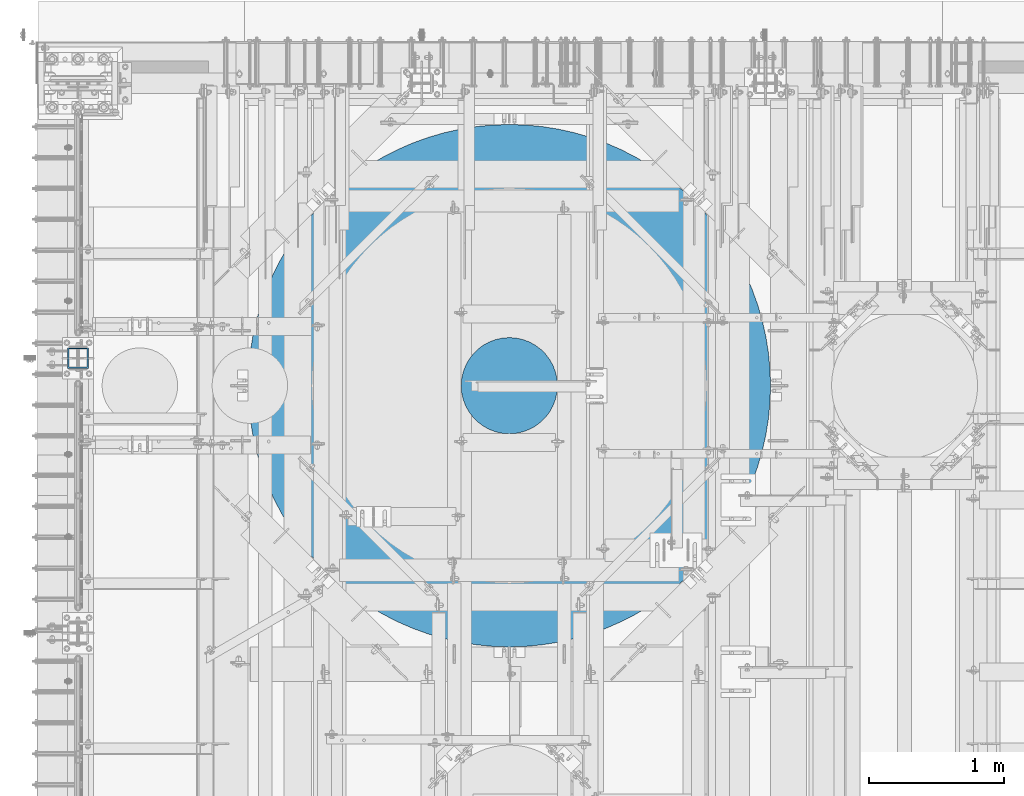
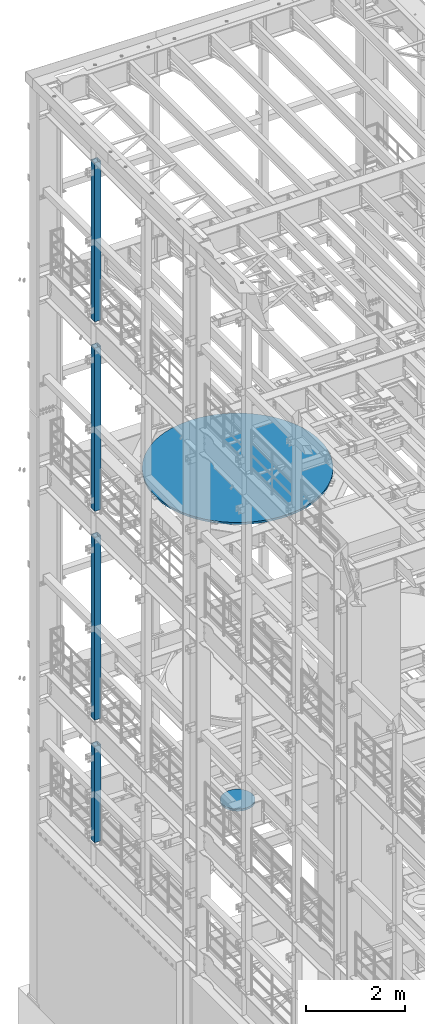
# One storey, part 743 of 1876: 6 columns, 6 elements without a shape of their own.
"""IFC2X3 building model written with IfcOpenShell, lengths in millimetres."""

from ifc_helpers import new_model, si_unit, frame, origin_with_axes, place, context, subcontext, project, spatial, faceted_brep, material, type_object, element, aggregate, save


model = new_model("IFC2X3")

# Units and contexts
model_context = context("Model", 3, precision=1e-05, world=origin_with_axes())
body_context = subcontext(model_context, "Body", "Model", "MODEL_VIEW")
ifc_project = project(units=[si_unit("LENGTHUNIT", "METRE", prefix="MILLI"), si_unit("AREAUNIT", "SQUARE_METRE"), si_unit("VOLUMEUNIT", "CUBIC_METRE"), si_unit("MASSUNIT", "GRAM", prefix="KILO"), si_unit("TIMEUNIT", "SECOND"), si_unit("PLANEANGLEUNIT", "RADIAN"), si_unit("SOLIDANGLEUNIT", "STERADIAN"), si_unit("THERMODYNAMICTEMPERATUREUNIT", "DEGREE_CELSIUS"), si_unit("LUMINOUSINTENSITYUNIT", "LUMEN")], contexts=[model_context])

# Site, building, storey
site_placement = place(None, origin_with_axes())
site = spatial("IfcSite", under=ifc_project, at=site_placement, CompositionType="ELEMENT")
building_placement = place(site_placement, origin_with_axes())
building = spatial("IfcBuilding", under=site, at=building_placement, Name="Undefined", CompositionType="ELEMENT")
storey_placement = place(building_placement, origin_with_axes())
storey = spatial("IfcBuildingStorey", under=building, at=storey_placement, Name="Undefined", CompositionType="ELEMENT", Elevation=0.0)

# Assembly, column
assembly_1_placement = place(storey_placement, origin_with_axes())
assembly_1 = element("IfcElementAssembly", 1, at=assembly_1_placement, inside=storey, Name="BEAM", AssemblyPlace="NOTDEFINED", PredefinedType="RIGID_FRAME")
ifc_material_1 = material()
column_type_1 = type_object("IfcColumnType", Name="HSS6X6X3/8", PredefinedType="NOTDEFINED")
column_1_placement = place(assembly_1_placement, frame((0.0, 11684.0, 17983.2), z_axis=(-1.0, 0.0, 0.0), x_axis=(0.0, 0.0, 1.0)))
column_1 = element("IfcColumn", 2, at=column_1_placement, type_object=column_type_1, material=ifc_material_1, Name="COLUMN", ObjectType="HSS6X6X3/8", context=body_context, shape_type="Brep", body=[
    faceted_brep([(12.7000000000016, 66.6750000000002, -66.6750000000002), (12.7000000000016, -66.6750000000002, -66.6750000000002), (3937.0, -66.6750000000002, -66.675), (3937.0, 66.6750000000002, -66.675), (12.7000000000016, -66.6750000000002, 66.6750000000002), (3937.0, -66.6750000000002, 66.675), (12.7000000000016, 66.6750000000002, 66.6750000000002), (3937.0, 66.6750000000002, 66.675), (12.7000000000016, 76.1999999999998, -76.1999999999998), (12.7000000000016, 76.1999999999998, 76.1999999999998), (3937.0, 76.1999999999998, 76.2), (3937.0, 76.1999999999998, -76.2), (12.7000000000016, -76.1999999999998, 76.1999999999998), (3937.0, -76.1999999999998, 76.2), (12.7000000000016, -76.1999999999998, -76.1999999999998), (3937.0, -76.1999999999998, -76.2)], [[[0, 1, 2, 3]], [[1, 4, 5, 2]], [[4, 6, 7, 5]], [[6, 0, 3, 7]], [[8, 9, 10, 11]], [[9, 12, 13, 10]], [[12, 14, 15, 13]], [[14, 8, 11, 15]], [[13, 15, 11, 10], [5, 7, 3, 2]], [[14, 12, 9, 8], [6, 4, 1, 0]]]),
])
aggregate(assembly_1, [column_1])

assembly_2_placement = place(storey_placement, origin_with_axes())
assembly_2 = element("IfcElementAssembly", 3, at=assembly_2_placement, inside=storey, Name="BEAM", AssemblyPlace="NOTDEFINED", PredefinedType="RIGID_FRAME")
column_2_placement = place(assembly_2_placement, frame((0.0, 11684.0, 13309.6), z_axis=(-1.0, 0.0, 0.0), x_axis=(0.0, 0.0, 1.0)))
column_2 = element("IfcColumn", 4, at=column_2_placement, type_object=column_type_1, material=ifc_material_1, Name="COLUMN", ObjectType="HSS6X6X3/8", context=body_context, shape_type="Brep", body=[
    faceted_brep([(12.7000000000016, 66.6750000000002, -66.6750000000002), (12.7000000000016, -66.6750000000002, -66.6750000000002), (4038.6, -66.6750000000002, -66.675), (4038.6, 66.6750000000002, -66.675), (12.7000000000016, -66.6750000000002, 66.6750000000002), (4038.6, -66.6750000000002, 66.675), (12.7000000000016, 66.6750000000002, 66.6750000000002), (4038.6, 66.6750000000002, 66.675), (12.7000000000016, 76.1999999999998, -76.1999999999998), (12.7000000000016, 76.1999999999998, 76.1999999999998), (4038.6, 76.1999999999998, 76.2), (4038.6, 76.1999999999998, -76.2), (12.7000000000016, -76.1999999999998, 76.1999999999998), (4038.6, -76.1999999999998, 76.2), (12.7000000000016, -76.1999999999998, -76.1999999999998), (4038.6, -76.1999999999998, -76.2)], [[[0, 1, 2, 3]], [[1, 4, 5, 2]], [[4, 6, 7, 5]], [[6, 0, 3, 7]], [[8, 9, 10, 11]], [[9, 12, 13, 10]], [[12, 14, 15, 13]], [[14, 8, 11, 15]], [[13, 15, 11, 10], [5, 7, 3, 2]], [[14, 12, 9, 8], [6, 4, 1, 0]]]),
])
aggregate(assembly_2, [column_2])

assembly_3_placement = place(storey_placement, origin_with_axes())
assembly_3 = element("IfcElementAssembly", 5, at=assembly_3_placement, inside=storey, Name="BEAM", AssemblyPlace="NOTDEFINED", PredefinedType="RIGID_FRAME")
column_3_placement = place(assembly_3_placement, frame((0.0, 11684.0, 8153.4), z_axis=(-0.999999999563517, 0.0, -2.95459999870218e-05), x_axis=(-2.95459999861759e-05, 0.0, 0.999999999563517)))
column_3 = element("IfcColumn", 6, at=column_3_placement, type_object=column_type_1, material=ifc_material_1, Name="COLUMN", ObjectType="HSS6X6X3/8", context=body_context, shape_type="Brep", body=[
    faceted_brep([(12.698030025992, 66.6750000000002, -66.675), (12.698030025992, -66.6750000000002, -66.675), (4521.2007045434, -66.6750000000002, -66.675), (4521.2007045434, 66.6750000000002, -66.675), (12.7019699850925, -66.6750000000002, 66.675), (4521.20070454334, -66.6750000000002, 66.675), (12.7019699850925, 66.6750000000002, 66.675), (4521.20070454334, 66.6750000000002, 66.675), (12.6977486003425, 76.1999999999998, -76.2), (12.7022514107421, 76.1999999999998, 76.2), (4521.20070454334, 76.1999999999998, 76.2), (4521.2007045434, 76.1999999999998, -76.2), (12.7022514107421, -76.1999999999998, 76.2), (4521.20070454334, -76.1999999999998, 76.2), (12.6977486003425, -76.1999999999998, -76.2), (4521.2007045434, -76.1999999999998, -76.2)], [[[0, 1, 2, 3]], [[1, 4, 5, 2]], [[4, 6, 7, 5]], [[6, 0, 3, 7]], [[8, 9, 10, 11]], [[9, 12, 13, 10]], [[12, 14, 15, 13]], [[14, 8, 11, 15]], [[13, 15, 11, 10], [5, 7, 3, 2]], [[14, 12, 9, 8], [6, 4, 1, 0]]]),
])
aggregate(assembly_3, [column_3])

assembly_4_placement = place(storey_placement, origin_with_axes())
assembly_4 = element("IfcElementAssembly", 7, at=assembly_4_placement, inside=storey, Name="BEAM", AssemblyPlace="NOTDEFINED", PredefinedType="RIGID_FRAME")
column_4_placement = place(assembly_4_placement, frame((0.0, 11684.0, 5130.8), z_axis=(-0.999999998434855, 0.0, -5.59490000241567e-05), x_axis=(-5.59490000243298e-05, 0.0, 0.999999998434855)))
column_4 = element("IfcColumn", 8, at=column_4_placement, type_object=column_type_1, material=ifc_material_1, Name="COLUMN", ObjectType="HSS6X6X3/8", context=body_context, shape_type="Brep", body=[
    faceted_brep([(12.6962696202891, 66.6750000000002, -66.675), (12.6962696202891, -66.6750000000002, -66.675), (2387.60070630699, -66.6750000000002, -66.675), (2387.60070630699, 66.6750000000002, -66.675), (12.7037304194646, -66.6750000000002, 66.675), (2387.600706307, -66.6750000000002, 66.675), (12.7037304194646, 66.6750000000002, 66.675), (2387.600706307, 66.6750000000002, 66.675), (12.6957367060613, 76.1999999999998, -76.2), (12.7042633336914, 76.1999999999998, 76.2), (2387.600706307, 76.1999999999998, 76.2), (2387.60070630699, 76.1999999999998, -76.2), (12.7042633336914, -76.1999999999998, 76.2), (2387.600706307, -76.1999999999998, 76.2), (12.6957367060613, -76.1999999999998, -76.2), (2387.60070630699, -76.1999999999998, -76.2)], [[[0, 1, 2, 3]], [[1, 4, 5, 2]], [[4, 6, 7, 5]], [[6, 0, 3, 7]], [[8, 9, 10, 11]], [[9, 12, 13, 10]], [[12, 14, 15, 13]], [[14, 8, 11, 15]], [[13, 15, 11, 10], [5, 7, 3, 2]], [[14, 12, 9, 8], [6, 4, 1, 0]]]),
])
aggregate(assembly_4, [column_4])

assembly_5_placement = place(storey_placement, origin_with_axes())
assembly_5 = element("IfcElementAssembly", 9, at=assembly_5_placement, inside=storey, Name="COLUMN", AssemblyPlace="NOTDEFINED", PredefinedType="REINFORCEMENT_UNIT")
ifc_material_2 = material(Name="CONCRETE/3000")
column_type_2 = type_object("IfcColumnType", PredefinedType="NOTDEFINED")
column_5_placement = place(assembly_5_placement, frame((3187.7, 11480.8, 13284.2), z_axis=(-1.0, 0.0, 0.0), x_axis=(0.0, 0.0, 1.0)))
column_5 = element("IfcColumn", 10, at=column_5_placement, type_object=column_type_2, material=ifc_material_2, Name="COLUMN", context=body_context, shape_type="Brep", body=[
    faceted_brep([(0.0, -1930.4, 0.0), (0.0, -1926.59079655794, -121.210818899386), (50.7999999999993, -1926.59079655794, -121.210818899386), (50.7999999999993, -1930.4, 0.0), (0.0, -1915.17821941747, -241.943274072532), (50.7999999999993, -1915.17821941747, -241.943274072532), (0.0, -1896.20730880666, -361.720889676283), (50.7999999999993, -1896.20730880666, -361.720889676283), (0.0, -1869.75293424271, -480.070958183035), (50.7999999999993, -1869.75293424271, -480.070958183035), (0.0, -1835.91949905616, -596.526405941398), (50.7999999999993, -1835.91949905616, -596.526405941398), (0.0, -1794.84052835868, -710.627636502502), (50.7999999999993, -1794.84052835868, -710.627636502502), (0.0, -1746.6781420804, -821.924344437215), (50.7999999999993, -1746.6781420804, -821.924344437215), (0.0, -1691.62241515667, -929.977292485952), (50.7999999999993, -1691.62241515667, -929.977292485952), (0.0, -1629.89062738909, -1034.36004502745), (50.7999999999993, -1629.89062738909, -1034.36004502745), (0.0, -1561.7264059414, -1134.66065102539), (50.7999999999993, -1561.7264059414, -1134.66065102539), (0.0, -1487.39876385438, -1230.48326981087), (50.7999999999993, -1487.39876385438, -1230.48326981087), (0.0, -1407.20103837429, -1321.44973328474), (50.7999999999993, -1407.20103837429, -1321.44973328474), (0.0, -1321.44973328474, -1407.20103837429), (50.7999999999993, -1321.44973328474, -1407.20103837429), (0.0, -1230.48326981087, -1487.39876385438), (50.7999999999993, -1230.48326981087, -1487.39876385438), (0.0, -1134.66065102539, -1561.7264059414), (50.7999999999993, -1134.66065102539, -1561.7264059414), (0.0, -1034.36004502746, -1629.89062738909), (50.7999999999993, -1034.36004502746, -1629.89062738909), (0.0, -929.977292485952, -1691.62241515667), (50.7999999999993, -929.977292485952, -1691.62241515667), (0.0, -821.924344437217, -1746.6781420804), (50.7999999999993, -821.924344437217, -1746.6781420804), (0.0, -710.627636502502, -1794.84052835868), (50.7999999999993, -710.627636502502, -1794.84052835868), (0.0, -596.526405941398, -1835.91949905616), (50.7999999999993, -596.526405941398, -1835.91949905616), (0.0, -480.070958183036, -1869.75293424271), (50.7999999999993, -480.070958183036, -1869.75293424271), (0.0, -361.720889676284, -1896.20730880666), (50.7999999999993, -361.720889676284, -1896.20730880666), (0.0, -241.943274072533, -1915.17821941747), (50.7999999999993, -241.943274072533, -1915.17821941747), (0.0, -121.210818899388, -1926.59079655794), (50.7999999999993, -121.210818899388, -1926.59079655794), (0.0, 0.0, -1930.4), (50.7999999999993, 0.0, -1930.4), (0.0, 121.210818899386, -1926.59079655794), (50.7999999999993, 121.210818899386, -1926.59079655794), (0.0, 241.943274072531, -1915.17821941747), (50.7999999999993, 241.943274072531, -1915.17821941747), (0.0, 361.720889676282, -1896.20730880666), (50.7999999999993, 361.720889676282, -1896.20730880666), (0.0, 480.070958183034, -1869.75293424271), (50.7999999999993, 480.070958183034, -1869.75293424271), (0.0, 596.526405941398, -1835.91949905616), (50.7999999999993, 596.526405941398, -1835.91949905616), (0.0, 710.627636502502, -1794.84052835868), (50.7999999999993, 710.627636502502, -1794.84052835868), (0.0, 821.924344437215, -1746.6781420804), (50.7999999999993, 821.924344437215, -1746.6781420804), (0.0, 929.977292485952, -1691.62241515667), (50.7999999999993, 929.977292485952, -1691.62241515667), (0.0, 1034.36004502746, -1629.89062738909), (50.7999999999993, 1034.36004502746, -1629.89062738909), (0.0, 1134.66065102539, -1561.7264059414), (50.7999999999993, 1134.66065102539, -1561.7264059414), (0.0, 1230.48326981087, -1487.39876385438), (50.7999999999993, 1230.48326981087, -1487.39876385438), (0.0, 1321.44973328474, -1407.20103837429), (50.7999999999993, 1321.44973328474, -1407.20103837429), (0.0, 1407.20103837429, -1321.44973328474), (50.7999999999993, 1407.20103837429, -1321.44973328474), (0.0, 1487.39876385438, -1230.48326981087), (50.7999999999993, 1487.39876385438, -1230.48326981087), (0.0, 1561.7264059414, -1134.66065102539), (50.7999999999993, 1561.7264059414, -1134.66065102539), (0.0, 1629.89062738909, -1034.36004502746), (50.7999999999993, 1629.89062738909, -1034.36004502746), (0.0, 1691.62241515667, -929.977292485952), (50.7999999999993, 1691.62241515667, -929.977292485952), (0.0, 1746.6781420804, -821.924344437216), (50.7999999999993, 1746.6781420804, -821.924344437216), (0.0, 1794.84052835868, -710.627636502503), (50.7999999999993, 1794.84052835868, -710.627636502503), (0.0, 1835.91949905616, -596.526405941399), (50.7999999999993, 1835.91949905616, -596.526405941399), (0.0, 1869.75293424271, -480.070958183036), (50.7999999999993, 1869.75293424271, -480.070958183036), (0.0, 1896.20730880666, -361.720889676283), (50.7999999999993, 1896.20730880666, -361.720889676283), (0.0, 1915.17821941747, -241.943274072533), (50.7999999999993, 1915.17821941747, -241.943274072533), (0.0, 1926.59079655794, -121.210818899387), (50.7999999999993, 1926.59079655794, -121.210818899387), (0.0, 1930.4, -4.54747350886464e-13), (50.7999999999993, 1930.4, -4.54747350886464e-13), (0.0, 1926.59079655794, 121.210818899386), (50.7999999999993, 1926.59079655794, 121.210818899386), (0.0, 1915.17821941747, 241.943274072532), (50.7999999999993, 1915.17821941747, 241.943274072532), (0.0, 1896.20730880666, 361.720889676283), (50.7999999999993, 1896.20730880666, 361.720889676283), (0.0, 1869.75293424271, 480.070958183036), (50.7999999999993, 1869.75293424271, 480.070958183036), (0.0, 1835.91949905616, 596.526405941398), (50.7999999999993, 1835.91949905616, 596.526405941398), (0.0, 1794.84052835868, 710.627636502502), (50.7999999999993, 1794.84052835868, 710.627636502502), (0.0, 1746.6781420804, 821.924344437216), (50.7999999999993, 1746.6781420804, 821.924344437216), (0.0, 1691.62241515667, 929.977292485951), (50.7999999999993, 1691.62241515667, 929.977292485951), (0.0, 1629.89062738909, 1034.36004502746), (50.7999999999993, 1629.89062738909, 1034.36004502746), (0.0, 1561.7264059414, 1134.66065102539), (50.7999999999993, 1561.7264059414, 1134.66065102539), (0.0, 1487.39876385438, 1230.48326981087), (50.7999999999993, 1487.39876385438, 1230.48326981087), (0.0, 1407.20103837429, 1321.44973328474), (50.7999999999993, 1407.20103837429, 1321.44973328474), (0.0, 1321.44973328474, 1407.20103837429), (50.7999999999993, 1321.44973328474, 1407.20103837429), (0.0, 1230.48326981087, 1487.39876385438), (50.7999999999993, 1230.48326981087, 1487.39876385438), (0.0, 1134.66065102539, 1561.7264059414), (50.7999999999993, 1134.66065102539, 1561.7264059414), (0.0, 1034.36004502746, 1629.89062738909), (50.7999999999993, 1034.36004502746, 1629.89062738909), (0.0, 929.977292485952, 1691.62241515667), (50.7999999999993, 929.977292485952, 1691.62241515667), (0.0, 821.924344437217, 1746.6781420804), (50.7999999999993, 821.924344437217, 1746.6781420804), (0.0, 710.627636502502, 1794.84052835868), (50.7999999999993, 710.627636502502, 1794.84052835868), (0.0, 596.526405941398, 1835.91949905616), (50.7999999999993, 596.526405941398, 1835.91949905616), (0.0, 480.070958183036, 1869.75293424271), (50.7999999999993, 480.070958183036, 1869.75293424271), (0.0, 361.720889676284, 1896.20730880666), (50.7999999999993, 361.720889676284, 1896.20730880666), (0.0, 241.943274072533, 1915.17821941747), (50.7999999999993, 241.943274072533, 1915.17821941747), (0.0, 121.210818899386, 1926.59079655794), (50.7999999999993, 121.210818899386, 1926.59079655794), (0.0, 0.0, 1930.4), (50.7999999999993, 0.0, 1930.4), (0.0, -121.210818899386, 1926.59079655794), (50.7999999999993, -121.210818899386, 1926.59079655794), (0.0, -241.943274072533, 1915.17821941747), (50.7999999999993, -241.943274072533, 1915.17821941747), (0.0, -361.720889676282, 1896.20730880666), (50.7999999999993, -361.720889676282, 1896.20730880666), (0.0, -480.070958183036, 1869.75293424271), (50.7999999999993, -480.070958183036, 1869.75293424271), (0.0, -596.526405941398, 1835.91949905616), (50.7999999999993, -596.526405941398, 1835.91949905616), (0.0, -710.627636502502, 1794.84052835868), (50.7999999999993, -710.627636502502, 1794.84052835868), (0.0, -821.924344437217, 1746.6781420804), (50.7999999999993, -821.924344437217, 1746.6781420804), (0.0, -929.977292485952, 1691.62241515667), (50.7999999999993, -929.977292485952, 1691.62241515667), (0.0, -1034.36004502746, 1629.89062738909), (50.7999999999993, -1034.36004502746, 1629.89062738909), (0.0, -1134.66065102539, 1561.7264059414), (50.7999999999993, -1134.66065102539, 1561.7264059414), (0.0, -1230.48326981087, 1487.39876385438), (50.7999999999993, -1230.48326981087, 1487.39876385438), (0.0, -1321.44973328474, 1407.20103837429), (50.7999999999993, -1321.44973328474, 1407.20103837429), (0.0, -1407.20103837429, 1321.44973328474), (50.7999999999993, -1407.20103837429, 1321.44973328474), (0.0, -1487.39876385438, 1230.48326981087), (50.7999999999993, -1487.39876385438, 1230.48326981087), (0.0, -1561.7264059414, 1134.66065102539), (50.7999999999993, -1561.7264059414, 1134.66065102539), (0.0, -1629.89062738909, 1034.36004502746), (50.7999999999993, -1629.89062738909, 1034.36004502746), (0.0, -1691.62241515667, 929.977292485951), (50.7999999999993, -1691.62241515667, 929.977292485951), (0.0, -1746.6781420804, 821.924344437216), (50.7999999999993, -1746.6781420804, 821.924344437216), (0.0, -1794.84052835868, 710.627636502502), (50.7999999999993, -1794.84052835868, 710.627636502502), (0.0, -1835.91949905616, 596.526405941398), (50.7999999999993, -1835.91949905616, 596.526405941398), (0.0, -1869.75293424271, 480.070958183036), (50.7999999999993, -1869.75293424271, 480.070958183036), (0.0, -1896.20730880666, 361.720889676283), (50.7999999999993, -1896.20730880666, 361.720889676283), (0.0, -1915.17821941747, 241.943274072533), (50.7999999999993, -1915.17821941747, 241.943274072533), (0.0, -1926.59079655794, 121.210818899387), (50.7999999999993, -1926.59079655794, 121.210818899387)], [[[0, 1, 2, 3]], [[1, 4, 5, 2]], [[4, 6, 7, 5]], [[6, 8, 9, 7]], [[8, 10, 11, 9]], [[10, 12, 13, 11]], [[12, 14, 15, 13]], [[14, 16, 17, 15]], [[16, 18, 19, 17]], [[18, 20, 21, 19]], [[20, 22, 23, 21]], [[22, 24, 25, 23]], [[24, 26, 27, 25]], [[26, 28, 29, 27]], [[28, 30, 31, 29]], [[30, 32, 33, 31]], [[32, 34, 35, 33]], [[34, 36, 37, 35]], [[36, 38, 39, 37]], [[38, 40, 41, 39]], [[40, 42, 43, 41]], [[42, 44, 45, 43]], [[44, 46, 47, 45]], [[46, 48, 49, 47]], [[48, 50, 51, 49]], [[50, 52, 53, 51]], [[52, 54, 55, 53]], [[54, 56, 57, 55]], [[56, 58, 59, 57]], [[58, 60, 61, 59]], [[60, 62, 63, 61]], [[62, 64, 65, 63]], [[64, 66, 67, 65]], [[66, 68, 69, 67]], [[68, 70, 71, 69]], [[70, 72, 73, 71]], [[72, 74, 75, 73]], [[74, 76, 77, 75]], [[76, 78, 79, 77]], [[78, 80, 81, 79]], [[80, 82, 83, 81]], [[82, 84, 85, 83]], [[84, 86, 87, 85]], [[86, 88, 89, 87]], [[88, 90, 91, 89]], [[90, 92, 93, 91]], [[92, 94, 95, 93]], [[94, 96, 97, 95]], [[96, 98, 99, 97]], [[98, 100, 101, 99]], [[100, 102, 103, 101]], [[102, 104, 105, 103]], [[104, 106, 107, 105]], [[106, 108, 109, 107]], [[108, 110, 111, 109]], [[110, 112, 113, 111]], [[112, 114, 115, 113]], [[114, 116, 117, 115]], [[116, 118, 119, 117]], [[118, 120, 121, 119]], [[120, 122, 123, 121]], [[122, 124, 125, 123]], [[124, 126, 127, 125]], [[126, 128, 129, 127]], [[128, 130, 131, 129]], [[130, 132, 133, 131]], [[132, 134, 135, 133]], [[134, 136, 137, 135]], [[136, 138, 139, 137]], [[138, 140, 141, 139]], [[140, 142, 143, 141]], [[142, 144, 145, 143]], [[144, 146, 147, 145]], [[146, 148, 149, 147]], [[148, 150, 151, 149]], [[150, 152, 153, 151]], [[152, 154, 155, 153]], [[154, 156, 157, 155]], [[156, 158, 159, 157]], [[158, 160, 161, 159]], [[160, 162, 163, 161]], [[162, 164, 165, 163]], [[164, 166, 167, 165]], [[166, 168, 169, 167]], [[168, 170, 171, 169]], [[170, 172, 173, 171]], [[172, 174, 175, 173]], [[174, 176, 177, 175]], [[176, 178, 179, 177]], [[178, 180, 181, 179]], [[180, 182, 183, 181]], [[182, 184, 185, 183]], [[184, 186, 187, 185]], [[186, 188, 189, 187]], [[188, 190, 191, 189]], [[190, 192, 193, 191]], [[192, 194, 195, 193]], [[194, 196, 197, 195]], [[196, 198, 199, 197]], [[198, 0, 3, 199]], [[5, 7, 9, 11, 13, 15, 17, 19, 21, 23, 25, 27, 29, 31, 33, 35, 37, 39, 41, 43, 45, 47, 49, 51, 53, 55, 57, 59, 61, 63, 65, 67, 69, 71, 73, 75, 77, 79, 81, 83, 85, 87, 89, 91, 93, 95, 97, 99, 101, 103, 105, 107, 109, 111, 113, 115, 117, 119, 121, 123, 125, 127, 129, 131, 133, 135, 137, 139, 141, 143, 145, 147, 149, 151, 153, 155, 157, 159, 161, 163, 165, 167, 169, 171, 173, 175, 177, 179, 181, 183, 185, 187, 189, 191, 193, 195, 197, 199, 3, 2]], [[198, 196, 194, 192, 190, 188, 186, 184, 182, 180, 178, 176, 174, 172, 170, 168, 166, 164, 162, 160, 158, 156, 154, 152, 150, 148, 146, 144, 142, 140, 138, 136, 134, 132, 130, 128, 126, 124, 122, 120, 118, 116, 114, 112, 110, 108, 106, 104, 102, 100, 98, 96, 94, 92, 90, 88, 86, 84, 82, 80, 78, 76, 74, 72, 70, 68, 66, 64, 62, 60, 58, 56, 54, 52, 50, 48, 46, 44, 42, 40, 38, 36, 34, 32, 30, 28, 26, 24, 22, 20, 18, 16, 14, 12, 10, 8, 6, 4, 1, 0]]]),
])
aggregate(assembly_5, [column_5])

assembly_6_placement = place(storey_placement, origin_with_axes())
assembly_6 = element("IfcElementAssembly", 11, at=assembly_6_placement, inside=storey, Name="COLUMN", AssemblyPlace="NOTDEFINED", PredefinedType="REINFORCEMENT_UNIT")
column_type_3 = type_object("IfcColumnType", PredefinedType="NOTDEFINED")
column_6_placement = place(assembly_6_placement, frame((3187.7, 11480.8, 5105.4), z_axis=(-1.0, 0.0, 0.0), x_axis=(0.0, 0.0, 1.0)))
column_6 = element("IfcColumn", 12, at=column_6_placement, type_object=column_type_3, material=ifc_material_2, Name="COLUMN", context=body_context, shape_type="Brep", body=[
    faceted_brep([(0.0, -355.6, 0.0), (0.0, -351.980504732859, -50.6071564899803), (50.7999999999993, -351.980504732859, -50.6071564899803), (50.7999999999993, -355.6, 0.0), (0.0, -341.195701417315, -100.184097212813), (50.7999999999993, -341.195701417315, -100.184097212813), (0.0, -323.465137548066, -147.721578623471), (50.7999999999993, -323.465137548066, -147.721578623471), (0.0, -299.149756274768, -192.251874687211), (50.7999999999993, -299.149756274768, -192.251874687211), (0.0, -268.744548640374, -232.868476990943), (50.7999999999993, -268.744548640374, -232.868476990943), (0.0, -232.868476990943, -268.744548640374), (50.7999999999993, -232.868476990943, -268.744548640374), (0.0, -192.25187468721, -299.149756274768), (50.7999999999993, -192.25187468721, -299.149756274768), (0.0, -147.72157862347, -323.465137548067), (50.7999999999993, -147.72157862347, -323.465137548067), (0.0, -100.184097212812, -341.195701417315), (50.7999999999993, -100.184097212812, -341.195701417315), (0.0, -50.6071564899794, -351.98050473286), (50.7999999999993, -50.6071564899794, -351.98050473286), (0.0, 0.0, -355.6), (50.7999999999993, 0.0, -355.6), (0.0, 50.6071564899794, -351.98050473286), (50.7999999999993, 50.6071564899794, -351.98050473286), (0.0, 100.184097212812, -341.195701417315), (50.7999999999993, 100.184097212812, -341.195701417315), (0.0, 147.72157862347, -323.465137548067), (50.7999999999993, 147.72157862347, -323.465137548067), (0.0, 192.25187468721, -299.149756274768), (50.7999999999993, 192.25187468721, -299.149756274768), (0.0, 232.868476990943, -268.744548640374), (50.7999999999993, 232.868476990943, -268.744548640374), (0.0, 268.744548640374, -232.868476990943), (50.7999999999993, 268.744548640374, -232.868476990943), (0.0, 299.149756274768, -192.251874687211), (50.7999999999993, 299.149756274768, -192.251874687211), (0.0, 323.465137548066, -147.721578623471), (50.7999999999993, 323.465137548066, -147.721578623471), (0.0, 341.195701417315, -100.184097212813), (50.7999999999993, 341.195701417315, -100.184097212813), (0.0, 351.980504732859, -50.6071564899803), (50.7999999999993, 351.980504732859, -50.6071564899803), (0.0, 355.6, 0.0), (50.7999999999993, 355.6, 0.0), (0.0, 351.980504732859, 50.6071564899803), (50.7999999999993, 351.980504732859, 50.6071564899803), (0.0, 341.195701417315, 100.184097212813), (50.7999999999993, 341.195701417315, 100.184097212813), (0.0, 323.465137548066, 147.721578623471), (50.7999999999993, 323.465137548066, 147.721578623471), (0.0, 299.149756274768, 192.251874687211), (50.7999999999993, 299.149756274768, 192.251874687211), (0.0, 268.744548640374, 232.868476990943), (50.7999999999993, 268.744548640374, 232.868476990943), (0.0, 232.868476990943, 268.744548640374), (50.7999999999993, 232.868476990943, 268.744548640374), (0.0, 192.25187468721, 299.149756274768), (50.7999999999993, 192.25187468721, 299.149756274768), (0.0, 147.72157862347, 323.465137548067), (50.7999999999993, 147.72157862347, 323.465137548067), (0.0, 100.184097212812, 341.195701417315), (50.7999999999993, 100.184097212812, 341.195701417315), (0.0, 50.6071564899794, 351.98050473286), (50.7999999999993, 50.6071564899794, 351.98050473286), (0.0, 0.0, 355.6), (50.7999999999993, 0.0, 355.6), (0.0, -50.6071564899794, 351.98050473286), (50.7999999999993, -50.6071564899794, 351.98050473286), (0.0, -100.184097212812, 341.195701417315), (50.7999999999993, -100.184097212812, 341.195701417315), (0.0, -147.72157862347, 323.465137548067), (50.7999999999993, -147.72157862347, 323.465137548067), (0.0, -192.25187468721, 299.149756274768), (50.7999999999993, -192.25187468721, 299.149756274768), (0.0, -232.868476990943, 268.744548640374), (50.7999999999993, -232.868476990943, 268.744548640374), (0.0, -268.744548640374, 232.868476990943), (50.7999999999993, -268.744548640374, 232.868476990943), (0.0, -299.149756274768, 192.251874687211), (50.7999999999993, -299.149756274768, 192.251874687211), (0.0, -323.465137548066, 147.721578623471), (50.7999999999993, -323.465137548066, 147.721578623471), (0.0, -341.195701417315, 100.184097212813), (50.7999999999993, -341.195701417315, 100.184097212813), (0.0, -351.980504732859, 50.6071564899803), (50.7999999999993, -351.980504732859, 50.6071564899803)], [[[0, 1, 2, 3]], [[1, 4, 5, 2]], [[4, 6, 7, 5]], [[6, 8, 9, 7]], [[8, 10, 11, 9]], [[10, 12, 13, 11]], [[12, 14, 15, 13]], [[14, 16, 17, 15]], [[16, 18, 19, 17]], [[18, 20, 21, 19]], [[20, 22, 23, 21]], [[22, 24, 25, 23]], [[24, 26, 27, 25]], [[26, 28, 29, 27]], [[28, 30, 31, 29]], [[30, 32, 33, 31]], [[32, 34, 35, 33]], [[34, 36, 37, 35]], [[36, 38, 39, 37]], [[38, 40, 41, 39]], [[40, 42, 43, 41]], [[42, 44, 45, 43]], [[44, 46, 47, 45]], [[46, 48, 49, 47]], [[48, 50, 51, 49]], [[50, 52, 53, 51]], [[52, 54, 55, 53]], [[54, 56, 57, 55]], [[56, 58, 59, 57]], [[58, 60, 61, 59]], [[60, 62, 63, 61]], [[62, 64, 65, 63]], [[64, 66, 67, 65]], [[66, 68, 69, 67]], [[68, 70, 71, 69]], [[70, 72, 73, 71]], [[72, 74, 75, 73]], [[74, 76, 77, 75]], [[76, 78, 79, 77]], [[78, 80, 81, 79]], [[80, 82, 83, 81]], [[82, 84, 85, 83]], [[84, 86, 87, 85]], [[86, 0, 3, 87]], [[5, 7, 9, 11, 13, 15, 17, 19, 21, 23, 25, 27, 29, 31, 33, 35, 37, 39, 41, 43, 45, 47, 49, 51, 53, 55, 57, 59, 61, 63, 65, 67, 69, 71, 73, 75, 77, 79, 81, 83, 85, 87, 3, 2]], [[86, 84, 82, 80, 78, 76, 74, 72, 70, 68, 66, 64, 62, 60, 58, 56, 54, 52, 50, 48, 46, 44, 42, 40, 38, 36, 34, 32, 30, 28, 26, 24, 22, 20, 18, 16, 14, 12, 10, 8, 6, 4, 1, 0]]]),
])
aggregate(assembly_6, [column_6])

save(model, "model.ifc")
